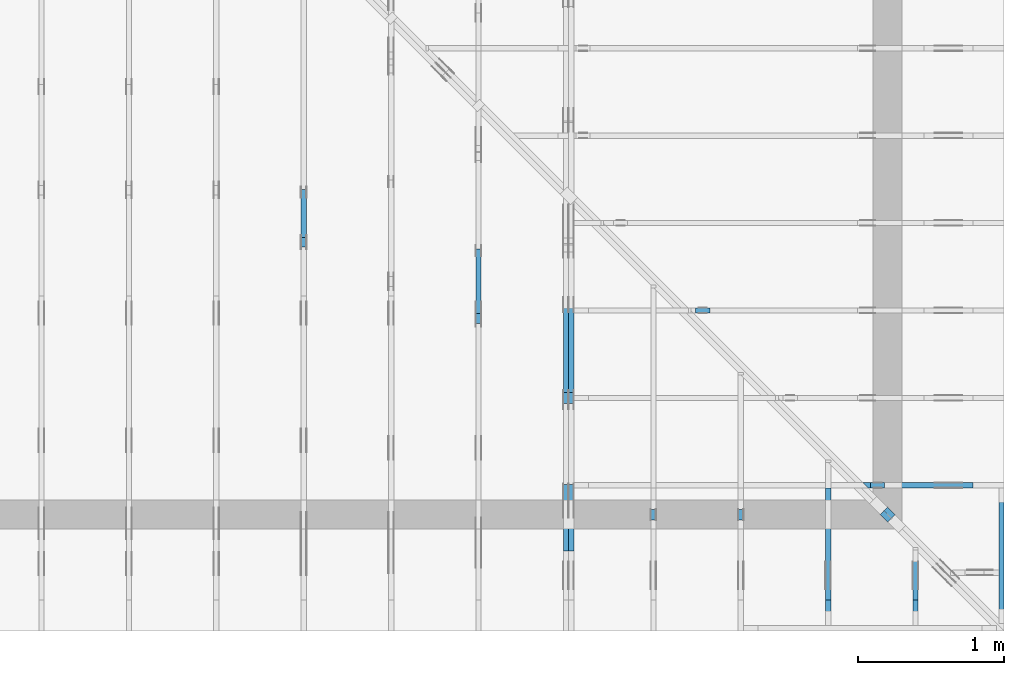
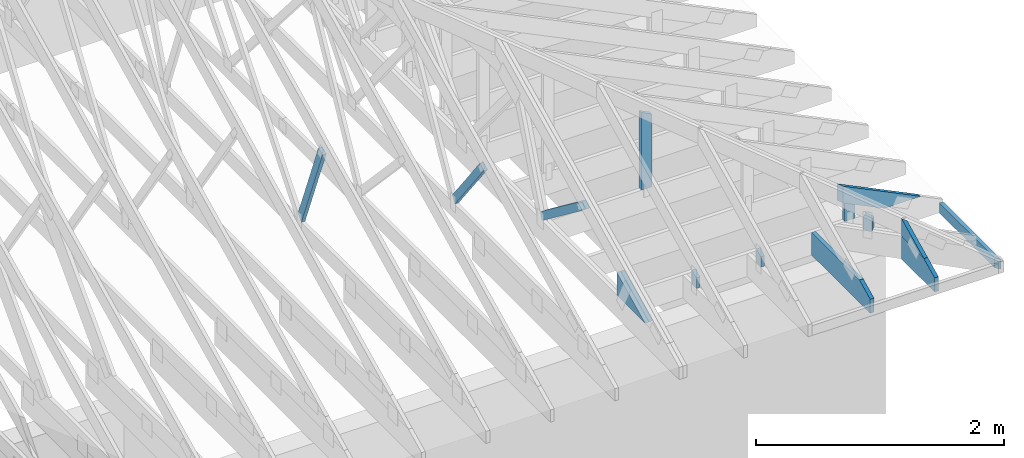
# One storey, part 48 of 159: 17 members, 11 elements without a shape of their own.
"""IFC2X3 building model written with IfcOpenShell, lengths in millimetres."""

from ifc_helpers import new_model, si_unit, frame, origin, origin_with_axes, origin_2d, place, context, project, spatial, faceted_brep, element, aggregate, save


model = new_model("IFC2X3")

# Units and contexts
model_context = context("Model", 3, precision=1e-05, world=origin())
plan_context = context("Plan", 2, precision=1e-05, world=origin_2d())
ifc_project = project(units=[si_unit("LENGTHUNIT", "METRE", prefix="MILLI"), si_unit("AREAUNIT", "SQUARE_METRE"), si_unit("VOLUMEUNIT", "CUBIC_METRE"), si_unit("SOLIDANGLEUNIT", "STERADIAN"), si_unit("PLANEANGLEUNIT", "RADIAN"), si_unit("MASSUNIT", "GRAM"), si_unit("TIMEUNIT", "SECOND"), si_unit("THERMODYNAMICTEMPERATUREUNIT", "DEGREE_CELSIUS"), si_unit("LUMINOUSINTENSITYUNIT", "LUMEN")], contexts=[model_context, plan_context])

# Site, building, storey
site_placement = place(None, origin_with_axes())
site = spatial("IfcSite", under=ifc_project, at=site_placement, CompositionType="ELEMENT")
building_placement = place(site_placement, origin_with_axes())
building = spatial("IfcBuilding", under=site, at=building_placement, Name="Plan 1", CompositionType="ELEMENT")
storey_placement = place(building_placement, origin_with_axes())
storey = spatial("IfcBuildingStorey", under=building, at=storey_placement, Name="Etasje 1", CompositionType="ELEMENT", Elevation=0.0)

# Assembly, member
assembly_1_placement = place(storey_placement, frame((16311.022261404749, -699.9989301294839, 1.1021457184401395e-15), z_axis=(1.0, -6.123031769111886e-17, 6.123031769111886e-17), x_axis=(6.123031769111886e-17, 1.0, 0.0)))
assembly_1 = element("IfcElementAssembly", 1, at=assembly_1_placement, inside=storey, Name="V8 (33)", AssemblyPlace="FACTORY", PredefinedType="TRUSS")
member_1_placement = place(assembly_1_placement, frame((2633.8831483091435, 1246.3258703737215, -35.99999999999999), z_axis=(0.0, 0.0, 1.0), x_axis=(0.36664062450611123, -0.9303626456719813, 0.0)))
member_1 = element("IfcMember", 2, at=member_1_placement, Name="V8-D53", context=model_context, shape_type="Brep", body=[
    faceted_brep([(900.3496376388703, 72.99991617681007, 36.0), (3.330005404222902e-05, 72.99991617681007, 36.0), (5.734237631680344, 4.614075578501797e-05, 36.0), (940.8437510807298, 4.614075578501797e-05, 36.0), (3.330005404222902e-05, 72.99991617681007, 4.07794577627422e-21), (900.3496376388703, 72.99991617681007, 1.1025738869142355e-13), (940.8437510807298, 4.614075578501797e-05, 1.1521632355275408e-13), (5.734237631680344, 4.614075578501797e-05, 7.02218383808313e-16), (5.734219593642479, 0.0, 0.0), (5.734219593642481, 1.6653345369377348e-16, 36.0), (-1.9539925233402755e-14, 73.0, 36.0), (-2.1316282072803006e-14, 73.0, 1.2818989709841442e-30), (940.843739208266, 6.572354763025976e-13, 1.544591251606393e-29), (940.843739208266, 6.594397677394778e-13, 36.0), (5.734219593642479, 6.668312475970883e-16, 36.0), (5.734219593642479, -1.5374601892831908e-15, 9.41391758272575e-32), (900.3496720570004, 73.00000000000136, -1.262177448353619e-29), (900.3496720570004, 73.00000000000136, 36.0), (940.8437392082658, 8.526512829121202e-13, 36.0), (940.8437392082658, 8.526512829121202e-13, -6.310887241768095e-30), (0.0, 73.0, 0.0), (0.0, 73.0, 36.0), (900.3496720570005, 73.00000000000134, 36.0), (900.3496720570005, 73.00000000000135, -1.5777218104420236e-30)], [[[0, 1, 2, 3]], [[4, 5, 6, 7]], [[8, 9, 10, 11]], [[12, 13, 14, 15]], [[16, 17, 18, 19]], [[20, 21, 22, 23]]]),
])
aggregate(assembly_1, [member_1])

# Assembly, members
assembly_2_placement = place(storey_placement, frame((18074.541652722903, -699.9989301294845, 4.408582873760558e-15), z_axis=(-1.0, 1.836909530733566e-16, 6.123031769111886e-17), x_axis=(-1.836909530733566e-16, -1.0, 0.0)))
assembly_2 = element("IfcElementAssembly", 3, at=assembly_2_placement, inside=storey, Name="V5 (30)", AssemblyPlace="FACTORY", PredefinedType="TRUSS")
member_2_placement = place(assembly_2_placement, frame((-1606.8070368798326, 775.6333018360349, -36.00000000000001), z_axis=(0.0, 0.0, 1.0), x_axis=(-0.7964129491037376, -0.6047531847786232, 0.0)))
member_2 = element("IfcMember", 4, at=member_2_placement, Name="V5-D60", context=model_context, shape_type="Brep", body=[
    faceted_brep([(817.681008437183, 72.99995299684588, 36.0), (7.70893598200928e-06, 72.99995299684588, 36.0), (36.85727069662994, 0.0, 36.0), (796.699838272749, 0.0, 36.0), (7.70893598200928e-06, 72.99995299684588, 9.440411984778511e-22), (817.681008437183, 72.99995299684588, 1.0013373583320631e-13), (796.699838272749, 0.0, 9.756436840380689e-14), (36.85727069662994, 0.0, 4.513564787964434e-15), (36.857230783051584, 2.0671424628915247e-05, 3.944304526105059e-31), (36.857230783051584, 2.0671424630691604e-05, 36.0), (2.842170943040401e-14, 73.00002067142441, 36.0), (2.4868995751603507e-14, 73.00002067142441, -1.9721522630525295e-30), (796.6998592319776, 2.0671424500703194e-05, -5.636630264904795e-30), (796.6998592319776, 2.0671424502907485e-05, 36.0), (36.85723078305159, 2.0671424642483702e-05, 36.0), (36.85723078305159, 2.067142464027941e-05, -2.6076395554347487e-31), (817.680919315021, 73.00002067142509, -1.8932661725304283e-29), (817.680919315021, 73.00002067142509, 36.0), (796.6998592319774, 2.067142443706871e-05, 36.0), (796.6998592319774, 2.067142443706871e-05, -1.8932661725304283e-29), (0.0, 73.00002067142441, 0.0), (0.0, 73.00002067142441, 36.0), (817.6809193150214, 73.00002067142526, 36.0), (817.6809193150214, 73.00002067142526, 1.1044052673094165e-29)], [[[0, 1, 2, 3]], [[4, 5, 6, 7]], [[8, 9, 10, 11]], [[12, 13, 14, 15]], [[16, 17, 18, 19]], [[20, 21, 22, 23]]]),
])
member_3_placement = place(assembly_2_placement, frame((-1606.8070368798326, 775.6333018360349, -72.00000000000001), z_axis=(0.0, 0.0, 1.0), x_axis=(-0.7964129491037376, -0.6047531847786232, 0.0)))
member_3 = element("IfcMember", 5, at=member_3_placement, Name="V5-D60", context=model_context, shape_type="Brep", body=[
    faceted_brep([(817.681008437183, 72.99995299684588, 36.0), (7.70893598200928e-06, 72.99995299684588, 36.0), (36.85727069662994, 0.0, 36.0), (796.699838272749, 0.0, 36.0), (7.70893598200928e-06, 72.99995299684588, 9.440411984778511e-22), (817.681008437183, 72.99995299684588, 1.0013373583320631e-13), (796.699838272749, 0.0, 9.756436840380689e-14), (36.85727069662994, 0.0, 4.513564787964434e-15), (36.857230783051584, 2.0671424628915247e-05, 3.944304526105059e-31), (36.857230783051584, 2.0671424630691604e-05, 36.0), (2.842170943040401e-14, 73.00002067142441, 36.0), (2.4868995751603507e-14, 73.00002067142441, -1.9721522630525295e-30), (796.6998592319776, 2.0671424500703194e-05, -5.636630264904795e-30), (796.6998592319776, 2.0671424502907485e-05, 36.0), (36.85723078305159, 2.0671424642483702e-05, 36.0), (36.85723078305159, 2.067142464027941e-05, -2.6076395554347487e-31), (817.680919315021, 73.00002067142509, -1.8932661725304283e-29), (817.680919315021, 73.00002067142509, 36.0), (796.6998592319774, 2.067142443706871e-05, 36.0), (796.6998592319774, 2.067142443706871e-05, -1.8932661725304283e-29), (0.0, 73.00002067142441, 0.0), (0.0, 73.00002067142441, 36.0), (817.6809193150214, 73.00002067142526, 36.0), (817.6809193150214, 73.00002067142526, 1.1044052673094165e-29)], [[[0, 1, 2, 3]], [[4, 5, 6, 7]], [[8, 9, 10, 11]], [[12, 13, 14, 15]], [[16, 17, 18, 19]], [[20, 21, 22, 23]]]),
])
member_4_placement = place(assembly_2_placement, frame((-1006.0125131974403, 223.0, -36.0), z_axis=(0.0, 0.0, 1.0), x_axis=(1.0, 0.0, 0.0)))
member_4 = element("IfcMember", 6, at=member_4_placement, Name="V5-KI3", context=model_context, shape_type="Brep", body=[
    faceted_brep([(9.90409034784534e-07, 223.0, 36.0), (9.90409034784534e-07, 0.0, 36.0), (457.21777442790903, 0.0, 36.0), (9.90409034784534e-07, 223.0, 0.0), (457.21777442790903, 0.0, 0.0), (9.90409034784534e-07, 0.0, 0.0), (0.0, 0.0, 0.0), (2.204291436880279e-15, -2.6993892992798474e-31, 36.0), (2.951301312711929e-14, 223.0, 36.0), (2.7308721690239013e-14, 223.0, -1.6721217048316832e-30), (457.2177566713128, -8.39867654850155e-14, 5.142536332496996e-30), (457.2177566713128, -8.178247404813522e-14, 36.0), (4.049083948919771e-31, 2.204291436880279e-15, 36.0), (0.0, 0.0, 0.0), (-4.263256414560601e-14, 222.99999999999994, -6.009650949938047e-30), (-4.263256414560601e-14, 222.99999999999994, 36.0), (457.2177566713128, -2.842170943040401e-14, 36.0), (457.2177566713128, -2.842170943040401e-14, -2.84404261991669e-30)], [[[0, 1, 2]], [[3, 4, 5]], [[6, 7, 8, 9]], [[10, 11, 12, 13]], [[14, 15, 16, 17]]]),
])
member_5_placement = place(assembly_2_placement, frame((-1006.0125131974403, 223.0, -72.0), z_axis=(0.0, 0.0, 1.0), x_axis=(1.0, 0.0, 0.0)))
member_5 = element("IfcMember", 7, at=member_5_placement, Name="V5-KI3", context=model_context, shape_type="Brep", body=[
    faceted_brep([(9.90409034784534e-07, 223.0, 36.0), (9.90409034784534e-07, 0.0, 36.0), (457.21777442790903, 0.0, 36.0), (9.90409034784534e-07, 223.0, 0.0), (457.21777442790903, 0.0, 0.0), (9.90409034784534e-07, 0.0, 0.0), (0.0, 0.0, 0.0), (2.204291436880279e-15, -2.6993892992798474e-31, 36.0), (2.951301312711929e-14, 223.0, 36.0), (2.7308721690239013e-14, 223.0, -1.6721217048316832e-30), (457.2177566713128, -8.39867654850155e-14, 5.142536332496996e-30), (457.2177566713128, -8.178247404813522e-14, 36.0), (4.049083948919771e-31, 2.204291436880279e-15, 36.0), (0.0, 0.0, 0.0), (-4.263256414560601e-14, 222.99999999999994, -6.009650949938047e-30), (-4.263256414560601e-14, 222.99999999999994, 36.0), (457.2177566713128, -2.842170943040401e-14, 36.0), (457.2177566713128, -2.842170943040401e-14, -2.84404261991669e-30)], [[[0, 1, 2]], [[3, 4, 5]], [[6, 7, 8, 9]], [[10, 11, 12, 13]], [[14, 15, 16, 17]]]),
])
aggregate(assembly_2, [member_2, member_3, member_4, member_5])

# Assembly, member
assembly_3_placement = place(storey_placement, frame((17475.02226140475, -699.9989301294827, 1.1021457184401395e-15), z_axis=(-1.0, 1.836909530733566e-16, 6.123031769111886e-17), x_axis=(-1.836909530733566e-16, -1.0, 0.0)))
assembly_3 = element("IfcElementAssembly", 8, at=assembly_3_placement, inside=storey, Name="V6 (31)", AssemblyPlace="FACTORY", PredefinedType="TRUSS")
member_6_placement = place(assembly_3_placement, frame((-2170.282971430428, 1029.9408266194846, -36.0), z_axis=(0.0, 0.0, 1.0), x_axis=(-0.6077192601697483, -0.7941519381193587, 0.0)))
member_6 = element("IfcMember", 9, at=member_6_placement, Name="V6-D62", context=model_context, shape_type="Brep", body=[
    faceted_brep([(773.8787217053492, 73.00005580777224, 36.0), (0.0, 73.00005580777224, 36.0), (14.752220936799858, 0.00016791371308499947, 36.0), (742.2077465606131, 0.00016791371308499947, 36.0), (0.0, 73.00005580777224, 0.0), (773.8787217053492, 73.00005580777224, 9.476967996883099e-14), (742.2077465606131, 0.00016791371308499947, 9.089123222943156e-14), (14.752220936799858, 0.00016791371308499947, 1.8065663492196607e-15), (14.75225105392087, 9.09717709869362e-05, 0.0), (14.752251053920872, 9.09717709873803e-05, 36.0), (2.0327715121837286e-05, 73.00009097177099, 36.0), (2.032771512006093e-05, 73.00009097177099, -8.874685183736383e-31), (742.2076767000625, 9.097177085104346e-05, 8.347947857844781e-30), (742.2076767000625, 9.097177085324775e-05, 36.0), (14.752251053920872, 9.097177098687473e-05, 36.0), (14.752251053920872, 9.097177098467044e-05, 1.659256355564211e-31), (773.8786947963424, 73.00009097177201, -1.8932661725304283e-29), (773.8786947963424, 73.00009097177201, 36.0), (742.2076767000624, 9.097177104422371e-05, 36.0), (742.2076767000624, 9.097177104422371e-05, -1.8932661725304283e-29), (2.0327715105850075e-05, 73.00009097177099, 0.0), (2.0327715105850075e-05, 73.00009097177099, 36.0), (773.8786947963425, 73.00009097177197, 36.0), (773.8786947963425, 73.00009097177197, 4.733165431326071e-30)], [[[0, 1, 2, 3]], [[4, 5, 6, 7]], [[8, 9, 10, 11]], [[12, 13, 14, 15]], [[16, 17, 18, 19]], [[20, 21, 22, 23]]]),
])
aggregate(assembly_3, [member_6])

assembly_4_placement = place(storey_placement, frame((19911.02226140475, -663.9989301290217, 1.1021457184401395e-15), z_axis=(1.0, -6.123031769111886e-17, 6.123031769111886e-17), x_axis=(6.123031769111886e-17, 1.0, 0.0)))
assembly_4 = element("IfcElementAssembly", 10, at=assembly_4_placement, inside=storey, Name="S22 (54)", AssemblyPlace="FACTORY", PredefinedType="TRUSS")
member_7_placement = place(assembly_4_placement, frame((946.00634765625, 223.00000000000128, -36.0), z_axis=(0.0, 0.0, 1.0), x_axis=(-1.0, -1.6538962040180127e-15, 0.0)))
member_7 = element("IfcMember", 11, at=member_7_placement, Name="S22-U22", context=model_context, shape_type="Brep", body=[
    faceted_brep([(946.0063476562614, 222.99999999999972, 36.0), (3.410605131648481e-13, 222.99999999999972, 36.0), (0.0, 1.2789769243681803e-12, 36.0), (770.8250579833984, 1.2789769243681803e-12, 36.0), (946.0063476567235, 85.44161987304659, 36.0), (3.410605131648481e-13, 222.99999999999972, 4.176648714595935e-29), (946.0063476562614, 222.99999999999972, 1.1584853840961584e-13), (946.0063476567235, 85.44161987304659, 1.1584853840967244e-13), (770.8250579833984, 1.2789769243681803e-12, 9.439572636919721e-14), (0.0, 1.2789769243681803e-12, 0.0), (1.6105968825286254e-05, 1.2789769243681803e-12, 0.0), (1.6105968827490546e-05, 1.2789769243681803e-12, 36.0), (1.610596915189495e-05, 223.00000000000128, 36.0), (1.6105969149690657e-05, 223.00000000000128, 1.0198588987734166e-30), (770.8250519745052, -2.3187699041427654e-13, 1.4197901788326666e-29), (770.8250519745052, -2.2967269897739626e-13, 36.0), (1.6105968825286254e-05, 1.2811812109601176e-12, 36.0), (1.6105968825286254e-05, 1.2789769195232373e-12, 2.9665740723479956e-37), (946.0063476567235, 85.44162681233115, 0.0), (946.0063476567235, 85.44162681233115, 36.0), (770.8250519745052, 0.0, 36.0), (770.8250519745052, 0.0, 0.0), (946.0063476570106, 222.99999999999972, 4.5880150247654047e-26), (946.0063476570106, 222.99999999999972, 36.0), (946.0063476570106, 85.4416268123311, 36.0), (946.0063476570106, 85.4416268123311, 1.758213185556591e-26), (1.6105969166346767e-05, 223.00000000000128, 0.0), (1.6105969166346767e-05, 223.00000000000128, 36.0), (946.0063476562614, 222.99999999999974, 36.0), (946.0063476562614, 222.99999999999974, 3.1554436208840472e-30)], [[[0, 1, 2, 3, 4]], [[5, 6, 7, 8, 9]], [[10, 11, 12, 13]], [[14, 15, 16, 17]], [[18, 19, 20, 21]], [[22, 23, 24, 25]], [[26, 27, 28, 29]]]),
])
aggregate(assembly_4, [member_7])

assembly_5_placement = place(storey_placement, frame((19311.02226140475, -699.9989301294839, 1.1021457184401395e-15), z_axis=(1.0, -6.123031769111886e-17, 6.123031769111886e-17), x_axis=(6.123031769111886e-17, 1.0, 0.0)))
assembly_5 = element("IfcElementAssembly", 12, at=assembly_5_placement, inside=storey, Name="S23 (53)", AssemblyPlace="FACTORY", PredefinedType="TRUSS")
member_8_placement = place(assembly_5_placement, frame((762.5, 362.835490555932, -36.0), z_axis=(0.0, 0.0, 1.0), x_axis=(-1.836909530733566e-16, -1.0, 0.0)))
member_8 = element("IfcMember", 13, at=member_8_placement, Name="S23-D72", context=model_context, shape_type="Brep", body=[
    faceted_brep([(139.83549055593195, 73.00000000000011, 36.0), (1.0819603801337507e-05, 73.00000000000011, 36.0), (35.60447248952573, 0.0, 36.0), (139.83549055593195, 0.0, 36.0), (1.0819603801337507e-05, 73.00000000000011, 1.3249755560958657e-21), (139.83549055593195, 73.00000000000011, 1.712434302246633e-14), (139.83549055593195, 0.0, 1.712434302246633e-14), (35.60447248952573, 0.0, 4.360146323516725e-15), (35.60447896533474, -1.7763568394002505e-15, 3.4633466240401087e-31), (35.60447896533475, 0.0, 36.0), (3.552713678800501e-15, 73.00000000000001, 36.0), (0.0, 73.00000000000001, -1.922479744743257e-31), (139.83549055593195, 5.967783702884803e-14, 3.3069882705980434e-30), (139.83549055593195, 6.188212846572831e-14, 36.0), (35.60447896533475, -1.1547312833676879e-14, 36.0), (35.60447896533475, -1.3751604270557158e-14, 8.420150982487615e-31), (139.83549055593195, 73.00000000000011, 0.0), (139.83549055593195, 73.00000000000011, 36.0), (139.83549055593195, 1.1368683772161603e-13, 36.0), (139.83549055593195, 1.1368683772161603e-13, 0.0), (0.0, 73.0, 0.0), (0.0, 73.0, 36.0), (139.83549055593195, 73.00000000000014, 36.0), (139.83549055593195, 73.00000000000014, 1.5777218104420236e-30)], [[[0, 1, 2, 3]], [[4, 5, 6, 7]], [[8, 9, 10, 11]], [[12, 13, 14, 15]], [[16, 17, 18, 19]], [[20, 21, 22, 23]]]),
])
aggregate(assembly_5, [member_8])

assembly_6_placement = place(storey_placement, frame((18711.02226140475, -699.9989301294839, 1.1021457184401395e-15), z_axis=(1.0, -6.123031769111886e-17, 6.123031769111886e-17), x_axis=(6.123031769111886e-17, 1.0, 0.0)))
assembly_6 = element("IfcElementAssembly", 14, at=assembly_6_placement, inside=storey, Name="S24 (52)", AssemblyPlace="FACTORY", PredefinedType="TRUSS")
member_9_placement = place(assembly_6_placement, frame((762.5, 362.83549055609916, -36.0), z_axis=(0.0, 0.0, 1.0), x_axis=(-1.836909530733566e-16, -1.0, 0.0)))
member_9 = element("IfcMember", 15, at=member_9_placement, Name="S24-D72", context=model_context, shape_type="Brep", body=[
    faceted_brep([(139.83549055609913, 73.00000000000011, 36.0), (1.0819770977832377e-05, 73.00000000000011, 36.0), (35.60447248969291, 0.0, 36.0), (139.83549055609913, 0.0, 36.0), (1.0819770977832377e-05, 73.00000000000011, 1.3249960286356485e-21), (139.83549055609913, 73.00000000000011, 1.7124343022486803e-14), (139.83549055609913, 0.0, 1.7124343022486803e-14), (35.60447248969291, 0.0, 4.3601463235371974e-15), (35.604478965377325, 0.0, 3.944304526105059e-31), (35.604478965377325, 1.7763568394002505e-15, 36.0), (7.105427357601002e-15, 73.00000000000001, 36.0), (3.552713678800501e-15, 73.00000000000001, -3.944304526105059e-31), (139.83549055609913, 5.967783702896581e-14, 3.3069882705908324e-30), (139.83549055609913, 6.188212846584609e-14, 36.0), (35.604478965377325, -1.1547312833646883e-14, 36.0), (35.604478965377325, -1.3751604270527162e-14, 8.42015098246925e-31), (139.83549055609913, 73.00000000000011, 0.0), (139.83549055609913, 73.00000000000011, 36.0), (139.83549055609913, 1.1368683772161603e-13, 36.0), (139.83549055609913, 1.1368683772161603e-13, 0.0), (0.0, 73.0, 0.0), (0.0, 73.0, 36.0), (139.83549055609913, 73.00000000000014, 36.0), (139.83549055609913, 73.00000000000014, 1.5777218104420236e-30)], [[[0, 1, 2, 3]], [[4, 5, 6, 7]], [[8, 9, 10, 11]], [[12, 13, 14, 15]], [[16, 17, 18, 19]], [[20, 21, 22, 23]]]),
])
aggregate(assembly_6, [member_9])

# Assembly, members
assembly_7_placement = place(storey_placement, frame((21100.012663101486, 318.00740142125824, 1.1021457184401395e-15), z_axis=(1.2246063538223773e-16, 1.0, 6.123031769111886e-17), x_axis=(-1.0, 1.2246063538223773e-16, 0.0)))
assembly_7 = element("IfcElementAssembly", 16, at=assembly_7_placement, inside=storey, Name="S20 (44)", AssemblyPlace="FACTORY", PredefinedType="TRUSS")
member_10_placement = place(assembly_7_placement, frame((276.06020909184946, 89.97847318829953, -36.000000218610595), z_axis=(0.0, 0.0, 1.0), x_axis=(0.8987940462991673, 0.43837114678907685, 0.0)))
member_10 = element("IfcMember", 17, at=member_10_placement, Name="S20-O72", context=model_context, shape_type="Brep", body=[
    faceted_brep([(841.0306763908294, 147.99999481821817, 36.00000324694793), (768.8462524414062, 7.030394044704735e-10, 36.00000021861058), (728.7925824997972, 3.2053540621745924e-07, 5.684341886080802e-14), (800.9770064492203, 147.9999951380505, 3.0283374599093804e-06), (3.5900364252938743e-05, 147.9999999999818, 2.186105945156669e-07), (3.5900364252938743e-05, 147.9999999999818, 36.000000218610595), (841.0306755488018, 147.99999999998175, 36.000000218610595), (800.9770065729717, 147.99999999998175, 2.186105945156669e-07), (1.5948346572258743e-05, 148.00000000036545, 2.1861059451566885e-07), (800.9770056944403, 148.00000000036545, 2.1861069260381992e-07), (728.7925803404363, 5.684341886080802e-14, 2.1861068376406934e-07), (303.4449927549872, 5.684341886080802e-14, 2.186106316757335e-07), (303.44498670843194, 1.0338965239498066e-09, 2.186105945156669e-07), (303.44498670843194, 1.0338965239498066e-09, 36.000000218610595), (1.4995300489317742e-05, 148.00000154197392, 36.000000218610595), (1.4995300489317742e-05, 148.00000154197392, 2.186105945156669e-07), (768.8462515628798, 7.314511778057759e-10, 36.000000218610595), (303.444987372206, 7.315366678075566e-10, 36.000000218610595), (303.444987372206, 7.314785082756787e-10, 2.186105945156669e-07), (728.7925825870498, 7.314003757705262e-10, 2.186105945156669e-07), (841.0306777954102, 148.00000000070315, 36.000000218610595), (0.0, 148.00000000070315, 36.000000218610595), (303.4449768066406, 1.033924945659237e-09, 36.000000218610595), (768.8462524414062, 1.033924945659237e-09, 36.000000218610595)], [[[0, 1, 2, 3]], [[4, 5, 6, 7]], [[8, 9, 10, 11]], [[12, 13, 14, 15]], [[16, 17, 18, 19]], [[20, 21, 22, 23]]]),
])
member_11_placement = place(assembly_7_placement, frame((819.0946433071513, 402.6318664550781, -36.0), z_axis=(0.0, 0.0, 1.0), x_axis=(-1.836909530733566e-16, -1.0, 0.0)))
member_11 = element("IfcMember", 18, at=member_11_placement, Name="S20-S13", context=model_context, shape_type="Brep", body=[
    faceted_brep([(179.63186645507812, 98.00002222019259, 36.0), (0.0, 98.00002222019259, 36.0), (47.79779052734375, 2.2220192477107048e-05, 36.0), (179.63186645507815, 2.2220192477107048e-05, 36.0), (0.0, 98.00002222019259, 0.0), (179.63186645507812, 98.00002222019259, 2.1997832500986142e-14), (179.63186645507815, 2.2220192477107048e-05, 2.1997832500986145e-14), (47.79779052734375, 2.2220192477107048e-05, 5.853347797845619e-15), (47.79780298576225, 7.105427357601002e-15, -4.589974164178181e-31), (47.79780298576226, 7.105427357601002e-15, 36.0), (9.306313593526738e-06, 98.0, 36.0), (9.306313593526738e-06, 98.0, -1.2300741234140647e-31), (179.63186645643037, 8.533005989237634e-14, 1.7362945151808217e-30), (179.63186645643037, 8.753435132925662e-14, 36.0), (47.797802985762246, -5.3410940603069815e-15, 36.0), (47.797802985762246, -7.54538549718726e-15, 4.62006351094737e-31), (179.63186645643037, 98.00000000000011, 3.74235613436848e-27), (179.63186645643037, 98.00000000000011, 36.0), (179.63186645643037, 1.1368683772161603e-13, 36.0), (179.63186645643037, 1.1368683772161603e-13, 0.0), (9.306313586421311e-06, 98.0, 0.0), (9.306313586421311e-06, 98.0, 36.0), (179.63186645636927, 98.00000000000014, 36.0), (179.63186645636927, 98.00000000000014, 2.3665827156630354e-30)], [[[0, 1, 2, 3]], [[4, 5, 6, 7]], [[8, 9, 10, 11]], [[12, 13, 14, 15]], [[16, 17, 18, 19]], [[20, 21, 22, 23]]]),
])
aggregate(assembly_7, [member_10, member_11])

# Assembly, member
assembly_8_placement = place(storey_placement, frame((21100.012663101486, 1518.0074014212582, 1.1021457184401395e-15), z_axis=(1.2246063538223773e-16, 1.0, 6.123031769111886e-17), x_axis=(-1.0, 1.2246063538223773e-16, 0.0)))
assembly_8 = element("IfcElementAssembly", 19, at=assembly_8_placement, inside=storey, Name="S18 (40)", AssemblyPlace="FACTORY", PredefinedType="TRUSS")
member_12_placement = place(assembly_8_placement, frame((2019.0946044921875, 987.9109634286215, -36.0), z_axis=(0.0, 0.0, 1.0), x_axis=(-1.836909530733566e-16, -1.0, 0.0)))
member_12 = element("IfcMember", 20, at=member_12_placement, Name="S18-S11", context=model_context, shape_type="Brep", body=[
    faceted_brep([(764.9109634286215, 98.00012207031273, 36.0), (1.3721590221393853e-05, 98.00012207031273, 36.0), (47.79780424893397, 0.0, 36.0), (764.9109634286215, 0.0, 36.0), (1.3721590221393853e-05, 98.00012207031273, 1.6803546569665913e-21), (764.9109634286215, 98.00012207031273, 9.367148259230859e-14), (764.9109634286215, 0.0, 9.367148259230859e-14), (47.79780424893397, 0.0, 5.8533494782002766e-15), (47.797793679405, 3.8814963776445666e-05, -3.944304526105059e-31), (47.797793679405004, 3.8814963776445666e-05, 36.0), (2.1316282072803006e-14, 98.00003881496401, 36.0), (2.1316282072803006e-14, 98.00003881496401, -1.9721522630525295e-30), (764.9109634292258, 3.881496361723058e-05, 2.3453419277097786e-29), (764.9109634292258, 3.881496361943487e-05, 36.0), (47.797793679405004, 3.8814963751162064e-05, 36.0), (47.797793679405004, 3.881496374895777e-05, 1.4655582083566184e-30), (764.9109634292258, 98.000038814964, 3.74235613436848e-27), (764.9109634292258, 98.000038814964, 36.0), (764.9109634292258, 3.881496400026663e-05, 36.0), (764.9109634292258, 3.881496400026663e-05, 0.0), (0.0, 98.000038814964, 0.0), (-1.3496946496399237e-31, 98.000038814964, 36.0), (764.9109634291648, 98.00003881496396, 36.0), (764.9109634291648, 98.00003881496396, -3.1554436208840472e-30)], [[[0, 1, 2, 3]], [[4, 5, 6, 7]], [[8, 9, 10, 11]], [[12, 13, 14, 15]], [[16, 17, 18, 19]], [[20, 21, 22, 23]]]),
])
aggregate(assembly_8, [member_12])

# Assembly, members
assembly_9_placement = place(storey_placement, frame((21125.46850722421, -674.5430860067681, 2.204291436880279e-15), z_axis=(0.707106781186546, 0.707106781186549, 6.123031769111886e-17), x_axis=(-0.707106781186549, 0.707106781186546, 0.0)))
assembly_9 = element("IfcElementAssembly", 21, at=assembly_9_placement, inside=storey, Name="GR1 (35)", AssemblyPlace="FACTORY", PredefinedType="TRUSS")
member_13_placement = place(assembly_9_placement, frame((1093.4566363361005, 353.3163288766036, -36.0), z_axis=(0.0, 0.0, 1.0), x_axis=(-1.836909530733566e-16, -1.0, 0.0)))
member_13 = element("IfcMember", 22, at=member_13_placement, Name="GR1-D75", context=model_context, shape_type="Brep", body=[
    faceted_brep([(130.31632887660362, 73.00002870296203, 36.0), (1.4179337995301466e-05, 73.00002870296203, 36.0), (25.176161640275495, 2.870296202672762e-05, 36.0), (130.31632887660365, 2.870296202672762e-05, 36.0), (1.4179337995301466e-05, 73.00002870296203, 1.7364107402041225e-21), (130.31632887660362, 73.00002870296203, 1.5958620434909532e-14), (130.31632887660365, 2.870296202672762e-05, 1.5958620434909535e-14), (25.176161640275495, 2.870296202672762e-05, 3.0830887509540575e-15), (25.17616851694908, 0.0, -1.9721522630525295e-31), (25.176168516949083, 8.881784197001252e-16, 36.0), (1.7763568394002505e-14, 73.00000000000001, 36.0), (1.4210854715202004e-14, 73.00000000000001, -9.860761315262648e-31), (130.31632887660365, -2.3937930652364306e-14, 1.4657270987122386e-30), (130.31632887660365, -2.1733639215484027e-14, 36.0), (25.176168516949076, -2.4203429527335313e-15, 36.0), (25.176168516949076, -4.62463438961381e-15, 2.831678328813272e-31), (130.31632887660365, 73.0, 1.5777218104420236e-30), (130.31632887660365, 73.0, 36.0), (130.31632887660365, 0.0, 36.0), (130.31632887660365, 0.0, 0.0), (0.0, 73.0, 0.0), (-1.3496946496399237e-31, 73.0, 36.0), (130.31632887660362, 72.99999999999999, 36.0), (130.31632887660362, 72.99999999999999, -7.888609052210118e-31)], [[[0, 1, 2, 3]], [[4, 5, 6, 7]], [[8, 9, 10, 11]], [[12, 13, 14, 15]], [[16, 17, 18, 19]], [[20, 21, 22, 23]]]),
])
member_14_placement = place(assembly_9_placement, frame((1093.4566363361005, 353.3163288766036, -72.0), z_axis=(0.0, 0.0, 1.0), x_axis=(-1.836909530733566e-16, -1.0, 0.0)))
member_14 = element("IfcMember", 23, at=member_14_placement, Name="GR1-D75", context=model_context, shape_type="Brep", body=[
    faceted_brep([(130.31632887660362, 73.00002870296203, 36.0), (1.4179337995301466e-05, 73.00002870296203, 36.0), (25.176161640275495, 2.870296202672762e-05, 36.0), (130.31632887660365, 2.870296202672762e-05, 36.0), (1.4179337995301466e-05, 73.00002870296203, 1.7364107402041225e-21), (130.31632887660362, 73.00002870296203, 1.5958620434909532e-14), (130.31632887660365, 2.870296202672762e-05, 1.5958620434909535e-14), (25.176161640275495, 2.870296202672762e-05, 3.0830887509540575e-15), (25.17616851694908, 0.0, -1.9721522630525295e-31), (25.176168516949083, 8.881784197001252e-16, 36.0), (1.7763568394002505e-14, 73.00000000000001, 36.0), (1.4210854715202004e-14, 73.00000000000001, -9.860761315262648e-31), (130.31632887660365, -2.3937930652364306e-14, 1.4657270987122386e-30), (130.31632887660365, -2.1733639215484027e-14, 36.0), (25.176168516949076, -2.4203429527335313e-15, 36.0), (25.176168516949076, -4.62463438961381e-15, 2.831678328813272e-31), (130.31632887660365, 73.0, 1.5777218104420236e-30), (130.31632887660365, 73.0, 36.0), (130.31632887660365, 0.0, 36.0), (130.31632887660365, 0.0, 0.0), (0.0, 73.0, 0.0), (-1.3496946496399237e-31, 73.0, 36.0), (130.31632887660362, 72.99999999999999, 36.0), (130.31632887660362, 72.99999999999999, -7.888609052210118e-31)], [[[0, 1, 2, 3]], [[4, 5, 6, 7]], [[8, 9, 10, 11]], [[12, 13, 14, 15]], [[16, 17, 18, 19]], [[20, 21, 22, 23]]]),
])
aggregate(assembly_9, [member_13, member_14])

assembly_10_placement = place(storey_placement, frame((20511.02226140475, -663.9989301290217, 1.1021457184401395e-15), z_axis=(1.0, -6.123031769111886e-17, 6.123031769111886e-17), x_axis=(6.123031769111886e-17, 1.0, 0.0)))
assembly_10 = element("IfcElementAssembly", 24, at=assembly_10_placement, inside=storey, Name="S21 (78)", AssemblyPlace="FACTORY", PredefinedType="TRUSS")
member_15_placement = place(assembly_10_placement, frame((240.06022132570848, 89.97847862605909, -36.0), z_axis=(0.0, 0.0, 1.0), x_axis=(0.898794046299167, 0.4383711467890774, 0.0)))
member_15 = element("IfcMember", 25, at=member_15_placement, Name="S21-O78", context=model_context, shape_type="Brep", body=[
    faceted_brep([(403.760375420316, 148.00000038689663, 4.599436920216249e-07), (363.70670842303036, 147.99999469395183, 35.999995394045484), (293.8134576147618, 4.6976045676760805, 36.0), (303.4449733720082, 4.556007979772403e-07, 25.283956878753116), (331.5759514693244, 3.295299393357709e-07, 1.1929665504339937e-06), (331.5759528683503, 4.765983305787813e-07, 0.0), (303.4449733303866, 4.765983305787813e-07, 25.28395652770996), (303.4449733303866, 4.765983305787813e-07, 0.0), (1.056289434586688e-05, 148.00000047746937, 0.0), (1.056289434586688e-05, 148.00000047746937, 36.0), (363.70670611953494, 148.00000047746934, 36.0), (403.76037509536513, 148.00000047746934, -1.5777218104420236e-30), (303.4449733289558, 4.765793590877365e-07, 3.9893443926075633e-07), (303.4449733289558, 4.765793590877365e-07, 25.2839569266444), (293.8134572561784, 4.697604742568771, 36.00000039893444), (1.6158243809627493e-06, 148.00000201751936, 36.00000039893446), (1.6158243809627493e-06, 148.00000201751936, 3.989344605770384e-07), (293.81345761476166, 4.697604567676109, 36.0), (363.7067071264804, 148.00000324931673, 36.0), (1.156983975647563e-05, 148.00000324931676, 36.0), (0.0, 148.00000047672694, 0.0), (403.7603759765625, 148.00000047672694, 4.9444752184261037e-14), (331.5759506225586, 4.775511115440167e-07, 4.060500159070801e-14), (303.4449768066405, 4.775511115440167e-07, 3.716006466328959e-14)], [[[0, 1, 2, 3, 4]], [[5, 6, 7]], [[8, 9, 10, 11]], [[12, 13, 14, 15, 16]], [[17, 18, 19]], [[20, 21, 22, 23]]]),
])
member_16_placement = place(assembly_10_placement, frame((538.0787353515509, 223.00000000000136, -36.00000168118806), z_axis=(0.0, 0.0, 1.0), x_axis=(-1.0, -2.542074623718138e-15, 0.0)))
member_16 = element("IfcMember", 26, at=member_16_placement, Name="S21-U30", context=model_context, shape_type="Brep", body=[
    faceted_brep([(2.083090019355092e-05, 1.283385507372939e-12, 6.113839005133208e-07), (36.00002190061611, 1.2789769243681801e-12, 36.00000168118775), (36.00002190061645, 223.00000000000128, 36.00000168118807), (2.083090020720528e-05, 223.00000000000128, 6.1138388685896e-07), (362.8974523205377, 1.2123159455864675e-12, 1.6811880598766038e-06), (362.8974523205377, 1.2145202370233478e-12, 36.00000168118806), (36.00002190061582, 1.2745683375744145e-12, 36.00000168118806), (2.1900615820413805e-05, 1.278976920448175e-12, 1.6811880598766038e-06), (2.190070142660261e-05, 223.00000000000136, 1.6811880598766038e-06), (36.00002190070143, 223.00000000000136, 36.00000168118806), (538.0787572522639, 223.00000000000134, 36.00000168118806), (538.0787572522639, 223.00000000000134, 1.6811880598766038e-06), (538.0787353520245, 85.44162681233112, 1.6811880598766038e-06), (538.0787353520245, 85.44162681233112, 36.00000168118806), (362.8974451114349, 2.6540595854385174e-06, 36.00000168118806), (362.8974451114349, 2.6540595854385174e-06, 1.6811880598766038e-06), (538.0787353523115, 222.99999997399357, 1.110461326447876e-06), (538.0787353523115, 222.99999997399357, 36.00000168118806), (538.0787353523115, 85.4416223904673, 36.00000226088839), (538.0787353523115, 85.4416223904673, 1.7569510081082375e-26), (538.0787267346009, 223.0, 36.00000168118806), (36.000021900616446, 223.0, 36.00000168118806), (36.00002190061582, 1.2789769243681803e-12, 36.00000168118806), (362.8974523205383, 1.2789769243681803e-12, 36.00000168118806), (538.0787267346008, 85.44161987304815, 36.00000168118806), (0.0, 223.00000000000136, 1.6811880598766038e-06), (538.0787353515625, 223.00000000000136, 1.6811881257700676e-06), (538.0787353520245, 85.44161987304688, 1.6811881257700676e-06), (362.897445678711, 0.0, 1.6811881043172555e-06), (0.0, 0.0, 1.6811880598766038e-06)], [[[0, 1, 2, 3]], [[4, 5, 6, 7]], [[8, 9, 10, 11]], [[12, 13, 14, 15]], [[16, 17, 18, 19]], [[20, 21, 22, 23, 24]], [[25, 26, 27, 28, 29]]]),
])
aggregate(assembly_10, [member_15, member_16])

# Assembly, member
assembly_11_placement = place(storey_placement, frame((21100.012663101486, -649.0872418840449, 0.0), z_axis=(1.0, -3.1247798944721017e-13, 6.123031769111886e-17), x_axis=(3.1247798944721017e-13, 1.0, 0.0)))
assembly_11 = element("IfcElementAssembly", 27, at=assembly_11_placement, inside=storey, Name="uu4 (1)", AssemblyPlace="FACTORY", PredefinedType="TRUSS")
member_17_placement = place(assembly_11_placement, frame((931.0946655273436, 98.00000000000153, -36.00000106980923), z_axis=(0.0, 0.0, 1.0), x_axis=(-1.0, -1.6538962040180127e-15, 0.0)))
member_17 = element("IfcMember", 28, at=member_17_placement, Name="uu4-U53", context=model_context, shape_type="Brep", body=[
    faceted_brep([(895.0946644576325, 98.0, -5.684341886080802e-14), (931.0946655273439, 98.0, 36.000001069809116), (931.0946655273439, 0.0, 36.000001069809116), (895.0946644576326, 0.0, 0.0), (-4.010877203864553e-39, 98.0, 1.0698092296479444e-06), (-1.3496946897486958e-31, 98.0, 36.00000106980923), (931.0946655273438, 97.99999999999994, 36.00000106980923), (895.0946655273438, 97.99999999999994, 1.0698092296479444e-06), (9.799805411603302e-11, 98.00000000000153, 1.0698092296479444e-06), (895.0946655274417, 98.00000000000153, 1.0698093392618058e-06), (895.0946655274416, 5.684341886080802e-14, 1.0698093392618058e-06), (9.78843672783114e-11, 5.684341886080802e-14, 1.0698092296479444e-06), (2.222204057034105e-05, 1.8270640111950343e-08, 2.0347774452034173e-06), (2.2222040572545342e-05, 1.8270640111950343e-08, 36.00000106980923), (2.2222040584546484e-05, 98.00000236466404, 36.00000289671789), (2.2222040582342193e-05, 98.00000236466404, 3.5328425482816783e-06), (931.0946655274416, -1.1198595614906087e-13, 36.00000106980923), (9.78843672783114e-11, 5.904771036317507e-14, 36.00000106980923), (9.78843672783114e-11, 5.684341892629479e-14, 1.0698092296479444e-06), (895.0946655274416, -1.0757737327530031e-13, 1.0698092296479444e-06), (931.0946655273438, 98.0, 36.00000106980923), (0.0, 98.0, 36.00000106980923), (0.0, 1.5489831639570184e-12, 36.00000106980923), (931.0946655273438, 1.5489831639570184e-12, 36.00000106980923)], [[[0, 1, 2, 3]], [[4, 5, 6, 7]], [[8, 9, 10, 11]], [[12, 13, 14, 15]], [[16, 17, 18, 19]], [[20, 21, 22, 23]]]),
])
aggregate(assembly_11, [member_17])

save(model, "model.ifc")
